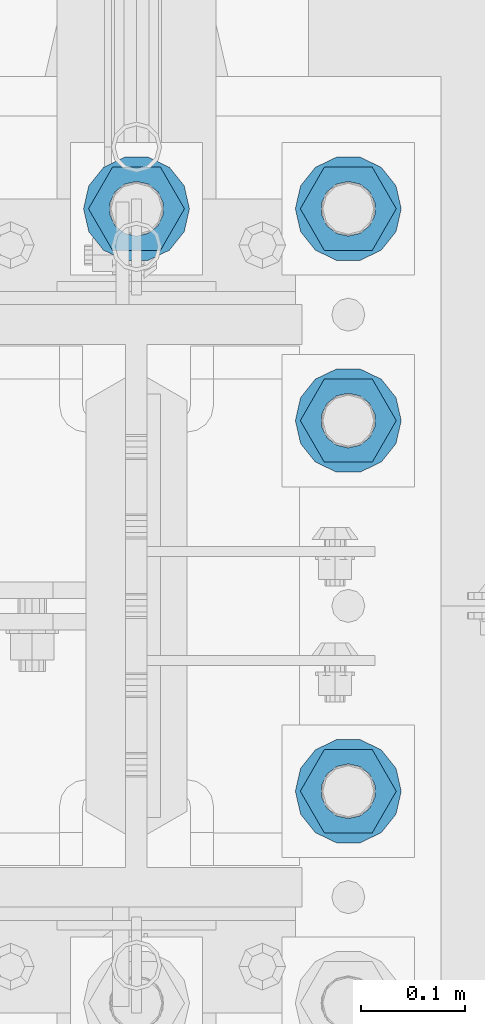
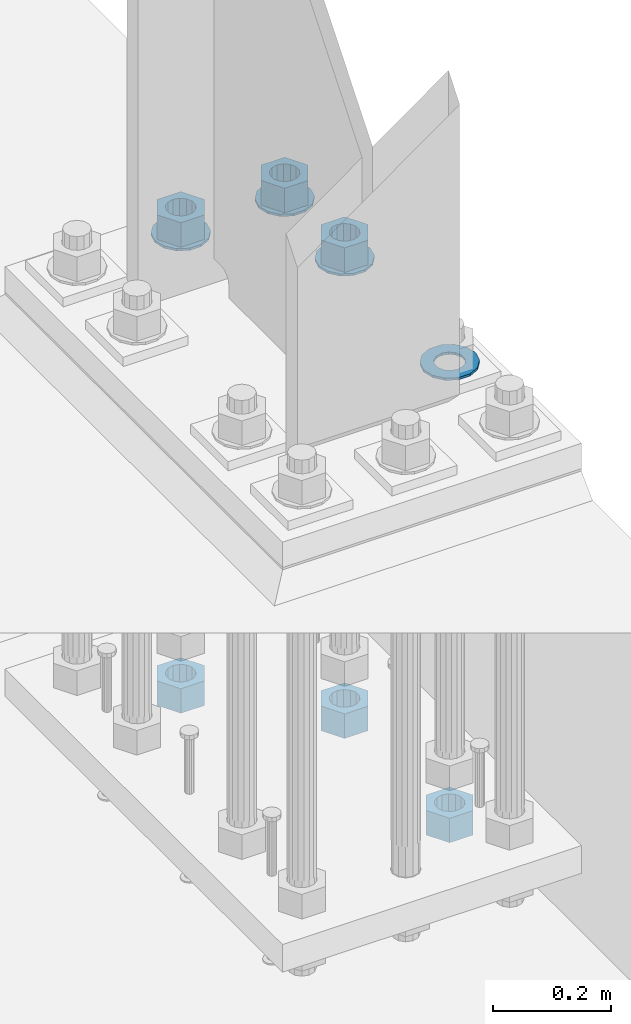
# One storey, part 843 of 1876: 10 columns, 1 element without a shape of its own.
"""IFC2X3 building model written with IfcOpenShell, lengths in millimetres."""

from ifc_helpers import new_model, si_unit, frame, origin_with_axes, place, context, subcontext, project, spatial, faceted_brep, material, type_object, element, aggregate, save


model = new_model("IFC2X3")

# Units and contexts
model_context = context("Model", 3, precision=1e-05, world=origin_with_axes())
body_context = subcontext(model_context, "Body", "Model", "MODEL_VIEW")
ifc_project = project(units=[si_unit("LENGTHUNIT", "METRE", prefix="MILLI"), si_unit("AREAUNIT", "SQUARE_METRE"), si_unit("VOLUMEUNIT", "CUBIC_METRE"), si_unit("MASSUNIT", "GRAM", prefix="KILO"), si_unit("TIMEUNIT", "SECOND"), si_unit("PLANEANGLEUNIT", "RADIAN"), si_unit("SOLIDANGLEUNIT", "STERADIAN"), si_unit("THERMODYNAMICTEMPERATUREUNIT", "DEGREE_CELSIUS"), si_unit("LUMINOUSINTENSITYUNIT", "LUMEN")], contexts=[model_context])

# Site, building, storey
site_placement = place(None, origin_with_axes())
site = spatial("IfcSite", under=ifc_project, at=site_placement, CompositionType="ELEMENT")
building_placement = place(site_placement, origin_with_axes())
building = spatial("IfcBuilding", under=site, at=building_placement, Name="Undefined", CompositionType="ELEMENT")
storey_placement = place(building_placement, origin_with_axes())
storey = spatial("IfcBuildingStorey", under=building, at=storey_placement, Name="Undefined", CompositionType="ELEMENT", Elevation=0.0)

# Assembly, columns
assembly_placement = place(storey_placement, origin_with_axes())
assembly = element("IfcElementAssembly", 1, at=assembly_placement, inside=storey, Name="TEMPLATE", AssemblyPlace="NOTDEFINED", PredefinedType="RIGID_FRAME")
ifc_material_1 = material(Name="STEEL/F436")
column_type_1 = type_object("IfcColumnType", Name="2_WASHER", PredefinedType="NOTDEFINED")
column_1_placement = place(assembly_placement, frame((7823.2, 1346.2, 119.0625), z_axis=(0.0, 1.0, 0.0), x_axis=(0.0, 0.0, -1.0)))
column_1 = element("IfcColumn", 2, at=column_1_placement, type_object=column_type_1, material=ifc_material_1, Name="WASHER", ObjectType="2_WASHER", context=body_context, shape_type="Brep", body=[
    faceted_brep([(0.0, -50.7999992370605, 9.09494701772928e-13), (0.0, -45.7692178020588, -22.0412936161442), (4.7625, -45.7692178020588, -22.0412936161442), (4.7625, -50.7999992370605, 9.09494701772928e-13), (0.0, -31.6732814587394, -39.7170387128856), (4.7625, -31.6732814587394, -39.7170387128856), (0.0, -11.3040632752118, -49.5263371950259), (4.7625, -11.3040632752118, -49.5263371950259), (0.0, 11.30406327521, -49.5263371950264), (4.7625, 11.30406327521, -49.5263371950264), (0.0, 31.6732814587385, -39.7170387128867), (4.7625, 31.6732814587385, -39.7170387128867), (0.0, 45.7692178020579, -22.041293616146), (4.7625, 45.7692178020579, -22.041293616146), (0.0, 50.7999992370605, -9.09494701772928e-13), (4.7625, 50.7999992370605, -9.09494701772928e-13), (0.0, 45.7692178020588, 22.0412936161442), (4.7625, 45.7692178020588, 22.0412936161442), (0.0, 31.6732814587394, 39.7170387128856), (4.7625, 31.6732814587394, 39.7170387128856), (0.0, 11.3040632752118, 49.5263371950259), (4.7625, 11.3040632752118, 49.5263371950259), (0.0, -11.30406327521, 49.5263371950264), (4.7625, -11.30406327521, 49.5263371950264), (0.0, -31.6732814587385, 39.7170387128867), (4.7625, -31.6732814587385, 39.7170387128867), (0.0, -45.7692178020579, 22.041293616146), (4.7625, -45.7692178020579, 22.041293616146), (0.0, 0.0, 26.9869995117188), (0.0, 11.7093983825444, 24.3146012721213), (4.7625, 11.7093983825444, 24.3146012721213), (4.7625, 0.0, 26.9869995117188), (0.0, 21.0996520289491, 16.8262864224157), (4.7625, 21.0996520289491, 16.8262864224157), (0.0, 26.3108629296712, 6.00524193584533), (4.7625, 26.3108629296712, 6.00524193584533), (0.0, 26.3108629296712, -6.00524193584533), (4.7625, 26.3108629296712, -6.00524193584533), (0.0, 21.0996520289491, -16.8262864224157), (4.7625, 21.0996520289491, -16.8262864224157), (0.0, 11.7093983825444, -24.3146012721213), (4.7625, 11.7093983825444, -24.3146012721213), (0.0, 0.0, -26.9869995117188), (4.7625, 0.0, -26.9869995117188), (0.0, -11.7093983825444, -24.3146012721213), (4.7625, -11.7093983825444, -24.3146012721213), (0.0, -21.0996520289491, -16.8262864224157), (4.7625, -21.0996520289491, -16.8262864224157), (0.0, -26.3108629296712, -6.00524193584533), (4.7625, -26.3108629296712, -6.00524193584533), (0.0, -26.3108629296712, 6.00524193584533), (4.7625, -26.3108629296712, 6.00524193584533), (0.0, -21.0996520289491, 16.8262864224157), (4.7625, -21.0996520289491, 16.8262864224157), (0.0, -11.7093983825444, 24.3146012721213), (4.7625, -11.7093983825444, 24.3146012721213)], [[[0, 1, 2, 3]], [[1, 4, 5, 2]], [[4, 6, 7, 5]], [[6, 8, 9, 7]], [[8, 10, 11, 9]], [[10, 12, 13, 11]], [[12, 14, 15, 13]], [[14, 16, 17, 15]], [[16, 18, 19, 17]], [[18, 20, 21, 19]], [[20, 22, 23, 21]], [[22, 24, 25, 23]], [[24, 26, 27, 25]], [[26, 0, 3, 27]], [[28, 29, 30, 31]], [[29, 32, 33, 30]], [[32, 34, 35, 33]], [[34, 36, 37, 35]], [[36, 38, 39, 37]], [[38, 40, 41, 39]], [[40, 42, 43, 41]], [[42, 44, 45, 43]], [[44, 46, 47, 45]], [[46, 48, 49, 47]], [[48, 50, 51, 49]], [[50, 52, 53, 51]], [[52, 54, 55, 53]], [[54, 28, 31, 55]], [[5, 7, 9, 11, 13, 15, 17, 19, 21, 23, 25, 27, 3, 2], [33, 35, 37, 39, 41, 43, 45, 47, 49, 51, 53, 55, 31, 30]], [[26, 24, 22, 20, 18, 16, 14, 12, 10, 8, 6, 4, 1, 0], [54, 52, 50, 48, 46, 44, 42, 40, 38, 36, 34, 32, 29, 28]]]),
])
column_2_placement = place(assembly_placement, frame((7823.2, 1701.8, 119.0625), z_axis=(0.0, 1.0, 0.0), x_axis=(0.0, 0.0, -1.0)))
column_2 = element("IfcColumn", 3, at=column_2_placement, type_object=column_type_1, material=ifc_material_1, Name="WASHER", ObjectType="2_WASHER", context=body_context, shape_type="Brep", body=[
    faceted_brep([(0.0, -50.7999992370605, 9.09494701772928e-13), (0.0, -45.7692178020588, -22.0412936161442), (4.7625, -45.7692178020588, -22.0412936161442), (4.7625, -50.7999992370605, 9.09494701772928e-13), (0.0, -31.6732814587394, -39.7170387128856), (4.7625, -31.6732814587394, -39.7170387128856), (0.0, -11.3040632752118, -49.5263371950259), (4.7625, -11.3040632752118, -49.5263371950259), (0.0, 11.30406327521, -49.5263371950264), (4.7625, 11.30406327521, -49.5263371950264), (0.0, 31.6732814587385, -39.7170387128867), (4.7625, 31.6732814587385, -39.7170387128867), (0.0, 45.7692178020579, -22.041293616146), (4.7625, 45.7692178020579, -22.041293616146), (0.0, 50.7999992370605, -9.09494701772928e-13), (4.7625, 50.7999992370605, -9.09494701772928e-13), (0.0, 45.7692178020588, 22.0412936161442), (4.7625, 45.7692178020588, 22.0412936161442), (0.0, 31.6732814587394, 39.7170387128856), (4.7625, 31.6732814587394, 39.7170387128856), (0.0, 11.3040632752118, 49.5263371950259), (4.7625, 11.3040632752118, 49.5263371950259), (0.0, -11.30406327521, 49.5263371950264), (4.7625, -11.30406327521, 49.5263371950264), (0.0, -31.6732814587385, 39.7170387128867), (4.7625, -31.6732814587385, 39.7170387128867), (0.0, -45.7692178020579, 22.041293616146), (4.7625, -45.7692178020579, 22.041293616146), (0.0, 0.0, 26.9869995117188), (0.0, 11.7093983825444, 24.3146012721213), (4.7625, 11.7093983825444, 24.3146012721213), (4.7625, 0.0, 26.9869995117188), (0.0, 21.0996520289491, 16.8262864224157), (4.7625, 21.0996520289491, 16.8262864224157), (0.0, 26.3108629296712, 6.00524193584533), (4.7625, 26.3108629296712, 6.00524193584533), (0.0, 26.3108629296712, -6.00524193584533), (4.7625, 26.3108629296712, -6.00524193584533), (0.0, 21.0996520289491, -16.8262864224157), (4.7625, 21.0996520289491, -16.8262864224157), (0.0, 11.7093983825444, -24.3146012721213), (4.7625, 11.7093983825444, -24.3146012721213), (0.0, 0.0, -26.9869995117188), (4.7625, 0.0, -26.9869995117188), (0.0, -11.7093983825444, -24.3146012721213), (4.7625, -11.7093983825444, -24.3146012721213), (0.0, -21.0996520289491, -16.8262864224157), (4.7625, -21.0996520289491, -16.8262864224157), (0.0, -26.3108629296712, -6.00524193584533), (4.7625, -26.3108629296712, -6.00524193584533), (0.0, -26.3108629296712, 6.00524193584533), (4.7625, -26.3108629296712, 6.00524193584533), (0.0, -21.0996520289491, 16.8262864224157), (4.7625, -21.0996520289491, 16.8262864224157), (0.0, -11.7093983825444, 24.3146012721213), (4.7625, -11.7093983825444, 24.3146012721213)], [[[0, 1, 2, 3]], [[1, 4, 5, 2]], [[4, 6, 7, 5]], [[6, 8, 9, 7]], [[8, 10, 11, 9]], [[10, 12, 13, 11]], [[12, 14, 15, 13]], [[14, 16, 17, 15]], [[16, 18, 19, 17]], [[18, 20, 21, 19]], [[20, 22, 23, 21]], [[22, 24, 25, 23]], [[24, 26, 27, 25]], [[26, 0, 3, 27]], [[28, 29, 30, 31]], [[29, 32, 33, 30]], [[32, 34, 35, 33]], [[34, 36, 37, 35]], [[36, 38, 39, 37]], [[38, 40, 41, 39]], [[40, 42, 43, 41]], [[42, 44, 45, 43]], [[44, 46, 47, 45]], [[46, 48, 49, 47]], [[48, 50, 51, 49]], [[50, 52, 53, 51]], [[52, 54, 55, 53]], [[54, 28, 31, 55]], [[5, 7, 9, 11, 13, 15, 17, 19, 21, 23, 25, 27, 3, 2], [33, 35, 37, 39, 41, 43, 45, 47, 49, 51, 53, 55, 31, 30]], [[26, 24, 22, 20, 18, 16, 14, 12, 10, 8, 6, 4, 1, 0], [54, 52, 50, 48, 46, 44, 42, 40, 38, 36, 34, 32, 29, 28]]]),
])
column_3_placement = place(assembly_placement, frame((7620.0, 1905.0, 119.0625), z_axis=(0.0, -1.0, 0.0), x_axis=(0.0, 0.0, -1.0)))
column_3 = element("IfcColumn", 4, at=column_3_placement, type_object=column_type_1, material=ifc_material_1, Name="WASHER", ObjectType="2_WASHER", context=body_context, shape_type="Brep", body=[
    faceted_brep([(0.0, -50.7999992370605, 9.09494701772928e-13), (0.0, -45.7692178020588, -22.0412936161442), (4.7625, -45.7692178020588, -22.0412936161442), (4.7625, -50.7999992370605, 9.09494701772928e-13), (0.0, -31.6732814587394, -39.7170387128856), (4.7625, -31.6732814587394, -39.7170387128856), (0.0, -11.3040632752118, -49.5263371950259), (4.7625, -11.3040632752118, -49.5263371950259), (0.0, 11.30406327521, -49.5263371950264), (4.7625, 11.30406327521, -49.5263371950264), (0.0, 31.6732814587385, -39.7170387128867), (4.7625, 31.6732814587385, -39.7170387128867), (0.0, 45.7692178020579, -22.041293616146), (4.7625, 45.7692178020579, -22.041293616146), (0.0, 50.7999992370605, -9.09494701772928e-13), (4.7625, 50.7999992370605, -9.09494701772928e-13), (0.0, 45.7692178020588, 22.0412936161442), (4.7625, 45.7692178020588, 22.0412936161442), (0.0, 31.6732814587394, 39.7170387128856), (4.7625, 31.6732814587394, 39.7170387128856), (0.0, 11.3040632752118, 49.5263371950259), (4.7625, 11.3040632752118, 49.5263371950259), (0.0, -11.30406327521, 49.5263371950264), (4.7625, -11.30406327521, 49.5263371950264), (0.0, -31.6732814587385, 39.7170387128867), (4.7625, -31.6732814587385, 39.7170387128867), (0.0, -45.7692178020579, 22.041293616146), (4.7625, -45.7692178020579, 22.041293616146), (0.0, 0.0, 26.9869995117188), (0.0, 11.7093983825444, 24.3146012721213), (4.7625, 11.7093983825444, 24.3146012721213), (4.7625, 0.0, 26.9869995117188), (0.0, 21.0996520289491, 16.8262864224157), (4.7625, 21.0996520289491, 16.8262864224157), (0.0, 26.3108629296712, 6.00524193584533), (4.7625, 26.3108629296712, 6.00524193584533), (0.0, 26.3108629296712, -6.00524193584533), (4.7625, 26.3108629296712, -6.00524193584533), (0.0, 21.0996520289491, -16.8262864224157), (4.7625, 21.0996520289491, -16.8262864224157), (0.0, 11.7093983825444, -24.3146012721213), (4.7625, 11.7093983825444, -24.3146012721213), (0.0, 0.0, -26.9869995117188), (4.7625, 0.0, -26.9869995117188), (0.0, -11.7093983825444, -24.3146012721213), (4.7625, -11.7093983825444, -24.3146012721213), (0.0, -21.0996520289491, -16.8262864224157), (4.7625, -21.0996520289491, -16.8262864224157), (0.0, -26.3108629296712, -6.00524193584533), (4.7625, -26.3108629296712, -6.00524193584533), (0.0, -26.3108629296712, 6.00524193584533), (4.7625, -26.3108629296712, 6.00524193584533), (0.0, -21.0996520289491, 16.8262864224157), (4.7625, -21.0996520289491, 16.8262864224157), (0.0, -11.7093983825444, 24.3146012721213), (4.7625, -11.7093983825444, 24.3146012721213)], [[[0, 1, 2, 3]], [[1, 4, 5, 2]], [[4, 6, 7, 5]], [[6, 8, 9, 7]], [[8, 10, 11, 9]], [[10, 12, 13, 11]], [[12, 14, 15, 13]], [[14, 16, 17, 15]], [[16, 18, 19, 17]], [[18, 20, 21, 19]], [[20, 22, 23, 21]], [[22, 24, 25, 23]], [[24, 26, 27, 25]], [[26, 0, 3, 27]], [[28, 29, 30, 31]], [[29, 32, 33, 30]], [[32, 34, 35, 33]], [[34, 36, 37, 35]], [[36, 38, 39, 37]], [[38, 40, 41, 39]], [[40, 42, 43, 41]], [[42, 44, 45, 43]], [[44, 46, 47, 45]], [[46, 48, 49, 47]], [[48, 50, 51, 49]], [[50, 52, 53, 51]], [[52, 54, 55, 53]], [[54, 28, 31, 55]], [[5, 7, 9, 11, 13, 15, 17, 19, 21, 23, 25, 27, 3, 2], [33, 35, 37, 39, 41, 43, 45, 47, 49, 51, 53, 55, 31, 30]], [[26, 24, 22, 20, 18, 16, 14, 12, 10, 8, 6, 4, 1, 0], [54, 52, 50, 48, 46, 44, 42, 40, 38, 36, 34, 32, 29, 28]]]),
])
column_4_placement = place(assembly_placement, frame((7823.2, 1905.0, 119.0625), z_axis=(0.0, 1.0, 0.0), x_axis=(0.0, 0.0, -1.0)))
column_4 = element("IfcColumn", 5, at=column_4_placement, type_object=column_type_1, material=ifc_material_1, Name="WASHER", ObjectType="2_WASHER", context=body_context, shape_type="Brep", body=[
    faceted_brep([(0.0, -50.7999992370605, 9.09494701772928e-13), (0.0, -45.7692178020588, -22.0412936161442), (4.7625, -45.7692178020588, -22.0412936161442), (4.7625, -50.7999992370605, 9.09494701772928e-13), (0.0, -31.6732814587394, -39.7170387128856), (4.7625, -31.6732814587394, -39.7170387128856), (0.0, -11.3040632752118, -49.5263371950259), (4.7625, -11.3040632752118, -49.5263371950259), (0.0, 11.30406327521, -49.5263371950264), (4.7625, 11.30406327521, -49.5263371950264), (0.0, 31.6732814587385, -39.7170387128867), (4.7625, 31.6732814587385, -39.7170387128867), (0.0, 45.7692178020579, -22.041293616146), (4.7625, 45.7692178020579, -22.041293616146), (0.0, 50.7999992370605, -9.09494701772928e-13), (4.7625, 50.7999992370605, -9.09494701772928e-13), (0.0, 45.7692178020588, 22.0412936161442), (4.7625, 45.7692178020588, 22.0412936161442), (0.0, 31.6732814587394, 39.7170387128856), (4.7625, 31.6732814587394, 39.7170387128856), (0.0, 11.3040632752118, 49.5263371950259), (4.7625, 11.3040632752118, 49.5263371950259), (0.0, -11.30406327521, 49.5263371950264), (4.7625, -11.30406327521, 49.5263371950264), (0.0, -31.6732814587385, 39.7170387128867), (4.7625, -31.6732814587385, 39.7170387128867), (0.0, -45.7692178020579, 22.041293616146), (4.7625, -45.7692178020579, 22.041293616146), (0.0, 0.0, 26.9869995117188), (0.0, 11.7093983825444, 24.3146012721213), (4.7625, 11.7093983825444, 24.3146012721213), (4.7625, 0.0, 26.9869995117188), (0.0, 21.0996520289491, 16.8262864224157), (4.7625, 21.0996520289491, 16.8262864224157), (0.0, 26.3108629296712, 6.00524193584533), (4.7625, 26.3108629296712, 6.00524193584533), (0.0, 26.3108629296712, -6.00524193584533), (4.7625, 26.3108629296712, -6.00524193584533), (0.0, 21.0996520289491, -16.8262864224157), (4.7625, 21.0996520289491, -16.8262864224157), (0.0, 11.7093983825444, -24.3146012721213), (4.7625, 11.7093983825444, -24.3146012721213), (0.0, 0.0, -26.9869995117188), (4.7625, 0.0, -26.9869995117188), (0.0, -11.7093983825444, -24.3146012721213), (4.7625, -11.7093983825444, -24.3146012721213), (0.0, -21.0996520289491, -16.8262864224157), (4.7625, -21.0996520289491, -16.8262864224157), (0.0, -26.3108629296712, -6.00524193584533), (4.7625, -26.3108629296712, -6.00524193584533), (0.0, -26.3108629296712, 6.00524193584533), (4.7625, -26.3108629296712, 6.00524193584533), (0.0, -21.0996520289491, 16.8262864224157), (4.7625, -21.0996520289491, 16.8262864224157), (0.0, -11.7093983825444, 24.3146012721213), (4.7625, -11.7093983825444, 24.3146012721213)], [[[0, 1, 2, 3]], [[1, 4, 5, 2]], [[4, 6, 7, 5]], [[6, 8, 9, 7]], [[8, 10, 11, 9]], [[10, 12, 13, 11]], [[12, 14, 15, 13]], [[14, 16, 17, 15]], [[16, 18, 19, 17]], [[18, 20, 21, 19]], [[20, 22, 23, 21]], [[22, 24, 25, 23]], [[24, 26, 27, 25]], [[26, 0, 3, 27]], [[28, 29, 30, 31]], [[29, 32, 33, 30]], [[32, 34, 35, 33]], [[34, 36, 37, 35]], [[36, 38, 39, 37]], [[38, 40, 41, 39]], [[40, 42, 43, 41]], [[42, 44, 45, 43]], [[44, 46, 47, 45]], [[46, 48, 49, 47]], [[48, 50, 51, 49]], [[50, 52, 53, 51]], [[52, 54, 55, 53]], [[54, 28, 31, 55]], [[5, 7, 9, 11, 13, 15, 17, 19, 21, 23, 25, 27, 3, 2], [33, 35, 37, 39, 41, 43, 45, 47, 49, 51, 53, 55, 31, 30]], [[26, 24, 22, 20, 18, 16, 14, 12, 10, 8, 6, 4, 1, 0], [54, 52, 50, 48, 46, 44, 42, 40, 38, 36, 34, 32, 29, 28]]]),
])
ifc_material_2 = material(Name="STEEL/A563")
column_type_2 = type_object("IfcColumnType", Name="2_HEAVY_HEX_NUT", PredefinedType="NOTDEFINED")
column_5_placement = place(assembly_placement, frame((7823.2, 1346.2, -793.75), z_axis=(0.0, 1.0, 0.0), x_axis=(0.0, 0.0, -1.0)))
column_5 = element("IfcColumn", 6, at=column_5_placement, type_object=column_type_2, material=ifc_material_2, Name="NUT", ObjectType="2_HEAVY_HEX_NUT", context=body_context, shape_type="Brep", body=[
    faceted_brep([(0.0, -46.0369987487793, 9.09494701772928e-13), (0.0, -23.0184993743896, -39.869213104248), (50.8, -23.0184993743896, -39.869213104248), (50.8, -46.0369987487793, 9.09494701772928e-13), (0.0, 23.0184993743896, -39.869213104248), (50.8, 23.0184993743896, -39.869213104248), (0.0, 46.0369987487793, -9.09494701772928e-13), (50.8, 46.0369987487793, -9.09494701772928e-13), (0.0, 23.0184993743896, 39.869213104248), (50.8, 23.0184993743896, 39.869213104248), (0.0, -23.0184993743896, 39.869213104248), (50.8, -23.0184993743896, 39.869213104248), (0.0, 0.0, 26.1940002441406), (0.0, 11.3650617044514, 23.5999013092769), (50.8, 11.3650617044513, 23.5999013092771), (50.8, 0.0, 26.1940002441406), (0.0, 20.4791109456437, 16.3316083006703), (50.8, 20.4791109456439, 16.3316083006703), (0.0, 25.5370200498346, 5.82867859874477), (50.8, 25.5370200498343, 5.82867859874455), (0.0, 25.5370200498346, -5.82867859874477), (50.8, 25.5370200498343, -5.82867859874455), (0.0, 20.4791109456437, -16.3316083006703), (50.8, 20.4791109456439, -16.3316083006703), (0.0, 11.3650617044514, -23.5999013092769), (50.8, 11.3650617044514, -23.5999013092771), (0.0, 0.0, -26.1940002441406), (50.8, 0.0, -26.1940002441406), (0.0, -11.3650617044514, -23.5999013092769), (50.8, -11.3650617044513, -23.5999013092771), (0.0, -20.4791109456437, -16.3316083006703), (50.8, -20.4791109456439, -16.3316083006703), (0.0, -25.5370200498346, -5.82867859874477), (50.8, -25.5370200498343, -5.82867859874455), (0.0, -25.5370200498346, 5.82867859874477), (50.8, -25.5370200498343, 5.82867859874455), (0.0, -20.4791109456437, 16.3316083006703), (50.8, -20.4791109456439, 16.3316083006703), (0.0, -11.3650617044514, 23.5999013092769), (50.8, -11.3650617044514, 23.5999013092771)], [[[0, 1, 2, 3]], [[1, 4, 5, 2]], [[4, 6, 7, 5]], [[6, 8, 9, 7]], [[8, 10, 11, 9]], [[10, 0, 3, 11]], [[12, 13, 14, 15]], [[13, 16, 17, 14]], [[16, 18, 19, 17]], [[18, 20, 21, 19]], [[20, 22, 23, 21]], [[22, 24, 25, 23]], [[24, 26, 27, 25]], [[26, 28, 29, 27]], [[28, 30, 31, 29]], [[30, 32, 33, 31]], [[32, 34, 35, 33]], [[34, 36, 37, 35]], [[36, 38, 39, 37]], [[38, 12, 15, 39]], [[5, 7, 9, 11, 3, 2], [17, 19, 21, 23, 25, 27, 29, 31, 33, 35, 37, 39, 15, 14]], [[10, 8, 6, 4, 1, 0], [38, 36, 34, 32, 30, 28, 26, 24, 22, 20, 18, 16, 13, 12]]]),
])
column_6_placement = place(assembly_placement, frame((7823.2, 1701.8, 169.8625), z_axis=(0.0, 1.0, 0.0), x_axis=(0.0, 0.0, -1.0)))
column_6 = element("IfcColumn", 7, at=column_6_placement, type_object=column_type_2, material=ifc_material_2, Name="NUT", ObjectType="2_HEAVY_HEX_NUT", context=body_context, shape_type="Brep", body=[
    faceted_brep([(0.0, -46.0369987487793, 9.09494701772928e-13), (0.0, -23.0184993743896, -39.869213104248), (50.8, -23.0184993743896, -39.869213104248), (50.8, -46.0369987487793, 9.09494701772928e-13), (0.0, 23.0184993743896, -39.869213104248), (50.8, 23.0184993743896, -39.869213104248), (0.0, 46.0369987487793, -9.09494701772928e-13), (50.8, 46.0369987487793, -9.09494701772928e-13), (0.0, 23.0184993743896, 39.869213104248), (50.8, 23.0184993743896, 39.869213104248), (0.0, -23.0184993743896, 39.869213104248), (50.8, -23.0184993743896, 39.869213104248), (0.0, 0.0, 26.1940002441406), (0.0, 11.3650617044514, 23.5999013092769), (50.8, 11.3650617044513, 23.5999013092771), (50.8, 0.0, 26.1940002441406), (0.0, 20.4791109456437, 16.3316083006703), (50.8, 20.4791109456439, 16.3316083006703), (0.0, 25.5370200498346, 5.82867859874477), (50.8, 25.5370200498343, 5.82867859874455), (0.0, 25.5370200498346, -5.82867859874477), (50.8, 25.5370200498343, -5.82867859874455), (0.0, 20.4791109456437, -16.3316083006703), (50.8, 20.4791109456439, -16.3316083006703), (0.0, 11.3650617044514, -23.5999013092769), (50.8, 11.3650617044514, -23.5999013092771), (0.0, 0.0, -26.1940002441406), (50.8, 0.0, -26.1940002441406), (0.0, -11.3650617044514, -23.5999013092769), (50.8, -11.3650617044513, -23.5999013092771), (0.0, -20.4791109456437, -16.3316083006703), (50.8, -20.4791109456439, -16.3316083006703), (0.0, -25.5370200498346, -5.82867859874477), (50.8, -25.5370200498343, -5.82867859874455), (0.0, -25.5370200498346, 5.82867859874477), (50.8, -25.5370200498343, 5.82867859874455), (0.0, -20.4791109456437, 16.3316083006703), (50.8, -20.4791109456439, 16.3316083006703), (0.0, -11.3650617044514, 23.5999013092769), (50.8, -11.3650617044514, 23.5999013092771)], [[[0, 1, 2, 3]], [[1, 4, 5, 2]], [[4, 6, 7, 5]], [[6, 8, 9, 7]], [[8, 10, 11, 9]], [[10, 0, 3, 11]], [[12, 13, 14, 15]], [[13, 16, 17, 14]], [[16, 18, 19, 17]], [[18, 20, 21, 19]], [[20, 22, 23, 21]], [[22, 24, 25, 23]], [[24, 26, 27, 25]], [[26, 28, 29, 27]], [[28, 30, 31, 29]], [[30, 32, 33, 31]], [[32, 34, 35, 33]], [[34, 36, 37, 35]], [[36, 38, 39, 37]], [[38, 12, 15, 39]], [[5, 7, 9, 11, 3, 2], [17, 19, 21, 23, 25, 27, 29, 31, 33, 35, 37, 39, 15, 14]], [[10, 8, 6, 4, 1, 0], [38, 36, 34, 32, 30, 28, 26, 24, 22, 20, 18, 16, 13, 12]]]),
])
column_7_placement = place(assembly_placement, frame((7823.2, 1701.8, -793.75), z_axis=(0.0, 1.0, 0.0), x_axis=(0.0, 0.0, -1.0)))
column_7 = element("IfcColumn", 8, at=column_7_placement, type_object=column_type_2, material=ifc_material_2, Name="NUT", ObjectType="2_HEAVY_HEX_NUT", context=body_context, shape_type="Brep", body=[
    faceted_brep([(0.0, -46.0369987487793, 9.09494701772928e-13), (0.0, -23.0184993743896, -39.869213104248), (50.8, -23.0184993743896, -39.869213104248), (50.8, -46.0369987487793, 9.09494701772928e-13), (0.0, 23.0184993743896, -39.869213104248), (50.8, 23.0184993743896, -39.869213104248), (0.0, 46.0369987487793, -9.09494701772928e-13), (50.8, 46.0369987487793, -9.09494701772928e-13), (0.0, 23.0184993743896, 39.869213104248), (50.8, 23.0184993743896, 39.869213104248), (0.0, -23.0184993743896, 39.869213104248), (50.8, -23.0184993743896, 39.869213104248), (0.0, 0.0, 26.1940002441406), (0.0, 11.3650617044514, 23.5999013092769), (50.8, 11.3650617044513, 23.5999013092771), (50.8, 0.0, 26.1940002441406), (0.0, 20.4791109456437, 16.3316083006703), (50.8, 20.4791109456439, 16.3316083006703), (0.0, 25.5370200498346, 5.82867859874477), (50.8, 25.5370200498343, 5.82867859874455), (0.0, 25.5370200498346, -5.82867859874477), (50.8, 25.5370200498343, -5.82867859874455), (0.0, 20.4791109456437, -16.3316083006703), (50.8, 20.4791109456439, -16.3316083006703), (0.0, 11.3650617044514, -23.5999013092769), (50.8, 11.3650617044514, -23.5999013092771), (0.0, 0.0, -26.1940002441406), (50.8, 0.0, -26.1940002441406), (0.0, -11.3650617044514, -23.5999013092769), (50.8, -11.3650617044513, -23.5999013092771), (0.0, -20.4791109456437, -16.3316083006703), (50.8, -20.4791109456439, -16.3316083006703), (0.0, -25.5370200498346, -5.82867859874477), (50.8, -25.5370200498343, -5.82867859874455), (0.0, -25.5370200498346, 5.82867859874477), (50.8, -25.5370200498343, 5.82867859874455), (0.0, -20.4791109456437, 16.3316083006703), (50.8, -20.4791109456439, 16.3316083006703), (0.0, -11.3650617044514, 23.5999013092769), (50.8, -11.3650617044514, 23.5999013092771)], [[[0, 1, 2, 3]], [[1, 4, 5, 2]], [[4, 6, 7, 5]], [[6, 8, 9, 7]], [[8, 10, 11, 9]], [[10, 0, 3, 11]], [[12, 13, 14, 15]], [[13, 16, 17, 14]], [[16, 18, 19, 17]], [[18, 20, 21, 19]], [[20, 22, 23, 21]], [[22, 24, 25, 23]], [[24, 26, 27, 25]], [[26, 28, 29, 27]], [[28, 30, 31, 29]], [[30, 32, 33, 31]], [[32, 34, 35, 33]], [[34, 36, 37, 35]], [[36, 38, 39, 37]], [[38, 12, 15, 39]], [[5, 7, 9, 11, 3, 2], [17, 19, 21, 23, 25, 27, 29, 31, 33, 35, 37, 39, 15, 14]], [[10, 8, 6, 4, 1, 0], [38, 36, 34, 32, 30, 28, 26, 24, 22, 20, 18, 16, 13, 12]]]),
])
column_8_placement = place(assembly_placement, frame((7620.0, 1905.0, 169.8625), z_axis=(0.0, -1.0, 0.0), x_axis=(0.0, 0.0, -1.0)))
column_8 = element("IfcColumn", 9, at=column_8_placement, type_object=column_type_2, material=ifc_material_2, Name="NUT", ObjectType="2_HEAVY_HEX_NUT", context=body_context, shape_type="Brep", body=[
    faceted_brep([(0.0, -46.0369987487793, 9.09494701772928e-13), (0.0, -23.0184993743896, -39.869213104248), (50.8, -23.0184993743896, -39.869213104248), (50.8, -46.0369987487793, 9.09494701772928e-13), (0.0, 23.0184993743896, -39.869213104248), (50.8, 23.0184993743896, -39.869213104248), (0.0, 46.0369987487793, -9.09494701772928e-13), (50.8, 46.0369987487793, -9.09494701772928e-13), (0.0, 23.0184993743896, 39.869213104248), (50.8, 23.0184993743896, 39.869213104248), (0.0, -23.0184993743896, 39.869213104248), (50.8, -23.0184993743896, 39.869213104248), (0.0, 0.0, 26.1940002441406), (0.0, 11.3650617044514, 23.5999013092769), (50.8, 11.3650617044513, 23.5999013092771), (50.8, 0.0, 26.1940002441406), (0.0, 20.4791109456437, 16.3316083006703), (50.8, 20.4791109456439, 16.3316083006703), (0.0, 25.5370200498346, 5.82867859874477), (50.8, 25.5370200498343, 5.82867859874455), (0.0, 25.5370200498346, -5.82867859874477), (50.8, 25.5370200498343, -5.82867859874455), (0.0, 20.4791109456437, -16.3316083006703), (50.8, 20.4791109456439, -16.3316083006703), (0.0, 11.3650617044514, -23.5999013092769), (50.8, 11.3650617044514, -23.5999013092771), (0.0, 0.0, -26.1940002441406), (50.8, 0.0, -26.1940002441406), (0.0, -11.3650617044514, -23.5999013092769), (50.8, -11.3650617044513, -23.5999013092771), (0.0, -20.4791109456437, -16.3316083006703), (50.8, -20.4791109456439, -16.3316083006703), (0.0, -25.5370200498346, -5.82867859874477), (50.8, -25.5370200498343, -5.82867859874455), (0.0, -25.5370200498346, 5.82867859874477), (50.8, -25.5370200498343, 5.82867859874455), (0.0, -20.4791109456437, 16.3316083006703), (50.8, -20.4791109456439, 16.3316083006703), (0.0, -11.3650617044514, 23.5999013092769), (50.8, -11.3650617044514, 23.5999013092771)], [[[0, 1, 2, 3]], [[1, 4, 5, 2]], [[4, 6, 7, 5]], [[6, 8, 9, 7]], [[8, 10, 11, 9]], [[10, 0, 3, 11]], [[12, 13, 14, 15]], [[13, 16, 17, 14]], [[16, 18, 19, 17]], [[18, 20, 21, 19]], [[20, 22, 23, 21]], [[22, 24, 25, 23]], [[24, 26, 27, 25]], [[26, 28, 29, 27]], [[28, 30, 31, 29]], [[30, 32, 33, 31]], [[32, 34, 35, 33]], [[34, 36, 37, 35]], [[36, 38, 39, 37]], [[38, 12, 15, 39]], [[5, 7, 9, 11, 3, 2], [17, 19, 21, 23, 25, 27, 29, 31, 33, 35, 37, 39, 15, 14]], [[10, 8, 6, 4, 1, 0], [38, 36, 34, 32, 30, 28, 26, 24, 22, 20, 18, 16, 13, 12]]]),
])
column_9_placement = place(assembly_placement, frame((7620.0, 1905.0, -793.75), z_axis=(0.0, -1.0, 0.0), x_axis=(0.0, 0.0, -1.0)))
column_9 = element("IfcColumn", 10, at=column_9_placement, type_object=column_type_2, material=ifc_material_2, Name="NUT", ObjectType="2_HEAVY_HEX_NUT", context=body_context, shape_type="Brep", body=[
    faceted_brep([(0.0, -46.0369987487793, 9.09494701772928e-13), (0.0, -23.0184993743896, -39.869213104248), (50.8, -23.0184993743896, -39.869213104248), (50.8, -46.0369987487793, 9.09494701772928e-13), (0.0, 23.0184993743896, -39.869213104248), (50.8, 23.0184993743896, -39.869213104248), (0.0, 46.0369987487793, -9.09494701772928e-13), (50.8, 46.0369987487793, -9.09494701772928e-13), (0.0, 23.0184993743896, 39.869213104248), (50.8, 23.0184993743896, 39.869213104248), (0.0, -23.0184993743896, 39.869213104248), (50.8, -23.0184993743896, 39.869213104248), (0.0, 0.0, 26.1940002441406), (0.0, 11.3650617044514, 23.5999013092769), (50.8, 11.3650617044513, 23.5999013092771), (50.8, 0.0, 26.1940002441406), (0.0, 20.4791109456437, 16.3316083006703), (50.8, 20.4791109456439, 16.3316083006703), (0.0, 25.5370200498346, 5.82867859874477), (50.8, 25.5370200498343, 5.82867859874455), (0.0, 25.5370200498346, -5.82867859874477), (50.8, 25.5370200498343, -5.82867859874455), (0.0, 20.4791109456437, -16.3316083006703), (50.8, 20.4791109456439, -16.3316083006703), (0.0, 11.3650617044514, -23.5999013092769), (50.8, 11.3650617044514, -23.5999013092771), (0.0, 0.0, -26.1940002441406), (50.8, 0.0, -26.1940002441406), (0.0, -11.3650617044514, -23.5999013092769), (50.8, -11.3650617044513, -23.5999013092771), (0.0, -20.4791109456437, -16.3316083006703), (50.8, -20.4791109456439, -16.3316083006703), (0.0, -25.5370200498346, -5.82867859874477), (50.8, -25.5370200498343, -5.82867859874455), (0.0, -25.5370200498346, 5.82867859874477), (50.8, -25.5370200498343, 5.82867859874455), (0.0, -20.4791109456437, 16.3316083006703), (50.8, -20.4791109456439, 16.3316083006703), (0.0, -11.3650617044514, 23.5999013092769), (50.8, -11.3650617044514, 23.5999013092771)], [[[0, 1, 2, 3]], [[1, 4, 5, 2]], [[4, 6, 7, 5]], [[6, 8, 9, 7]], [[8, 10, 11, 9]], [[10, 0, 3, 11]], [[12, 13, 14, 15]], [[13, 16, 17, 14]], [[16, 18, 19, 17]], [[18, 20, 21, 19]], [[20, 22, 23, 21]], [[22, 24, 25, 23]], [[24, 26, 27, 25]], [[26, 28, 29, 27]], [[28, 30, 31, 29]], [[30, 32, 33, 31]], [[32, 34, 35, 33]], [[34, 36, 37, 35]], [[36, 38, 39, 37]], [[38, 12, 15, 39]], [[5, 7, 9, 11, 3, 2], [17, 19, 21, 23, 25, 27, 29, 31, 33, 35, 37, 39, 15, 14]], [[10, 8, 6, 4, 1, 0], [38, 36, 34, 32, 30, 28, 26, 24, 22, 20, 18, 16, 13, 12]]]),
])
column_10_placement = place(assembly_placement, frame((7823.2, 1905.0, 169.8625), z_axis=(0.0, 1.0, 0.0), x_axis=(0.0, 0.0, -1.0)))
column_10 = element("IfcColumn", 11, at=column_10_placement, type_object=column_type_2, material=ifc_material_2, Name="NUT", ObjectType="2_HEAVY_HEX_NUT", context=body_context, shape_type="Brep", body=[
    faceted_brep([(0.0, -46.0369987487793, 9.09494701772928e-13), (0.0, -23.0184993743896, -39.869213104248), (50.8, -23.0184993743896, -39.869213104248), (50.8, -46.0369987487793, 9.09494701772928e-13), (0.0, 23.0184993743896, -39.869213104248), (50.8, 23.0184993743896, -39.869213104248), (0.0, 46.0369987487793, -9.09494701772928e-13), (50.8, 46.0369987487793, -9.09494701772928e-13), (0.0, 23.0184993743896, 39.869213104248), (50.8, 23.0184993743896, 39.869213104248), (0.0, -23.0184993743896, 39.869213104248), (50.8, -23.0184993743896, 39.869213104248), (0.0, 0.0, 26.1940002441406), (0.0, 11.3650617044514, 23.5999013092769), (50.8, 11.3650617044513, 23.5999013092771), (50.8, 0.0, 26.1940002441406), (0.0, 20.4791109456437, 16.3316083006703), (50.8, 20.4791109456439, 16.3316083006703), (0.0, 25.5370200498346, 5.82867859874477), (50.8, 25.5370200498343, 5.82867859874455), (0.0, 25.5370200498346, -5.82867859874477), (50.8, 25.5370200498343, -5.82867859874455), (0.0, 20.4791109456437, -16.3316083006703), (50.8, 20.4791109456439, -16.3316083006703), (0.0, 11.3650617044514, -23.5999013092769), (50.8, 11.3650617044514, -23.5999013092771), (0.0, 0.0, -26.1940002441406), (50.8, 0.0, -26.1940002441406), (0.0, -11.3650617044514, -23.5999013092769), (50.8, -11.3650617044513, -23.5999013092771), (0.0, -20.4791109456437, -16.3316083006703), (50.8, -20.4791109456439, -16.3316083006703), (0.0, -25.5370200498346, -5.82867859874477), (50.8, -25.5370200498343, -5.82867859874455), (0.0, -25.5370200498346, 5.82867859874477), (50.8, -25.5370200498343, 5.82867859874455), (0.0, -20.4791109456437, 16.3316083006703), (50.8, -20.4791109456439, 16.3316083006703), (0.0, -11.3650617044514, 23.5999013092769), (50.8, -11.3650617044514, 23.5999013092771)], [[[0, 1, 2, 3]], [[1, 4, 5, 2]], [[4, 6, 7, 5]], [[6, 8, 9, 7]], [[8, 10, 11, 9]], [[10, 0, 3, 11]], [[12, 13, 14, 15]], [[13, 16, 17, 14]], [[16, 18, 19, 17]], [[18, 20, 21, 19]], [[20, 22, 23, 21]], [[22, 24, 25, 23]], [[24, 26, 27, 25]], [[26, 28, 29, 27]], [[28, 30, 31, 29]], [[30, 32, 33, 31]], [[32, 34, 35, 33]], [[34, 36, 37, 35]], [[36, 38, 39, 37]], [[38, 12, 15, 39]], [[5, 7, 9, 11, 3, 2], [17, 19, 21, 23, 25, 27, 29, 31, 33, 35, 37, 39, 15, 14]], [[10, 8, 6, 4, 1, 0], [38, 36, 34, 32, 30, 28, 26, 24, 22, 20, 18, 16, 13, 12]]]),
])
aggregate(assembly, [column_1, column_5, column_6, column_2, column_7, column_8, column_3, column_9, column_10, column_4])

save(model, "model.ifc")
